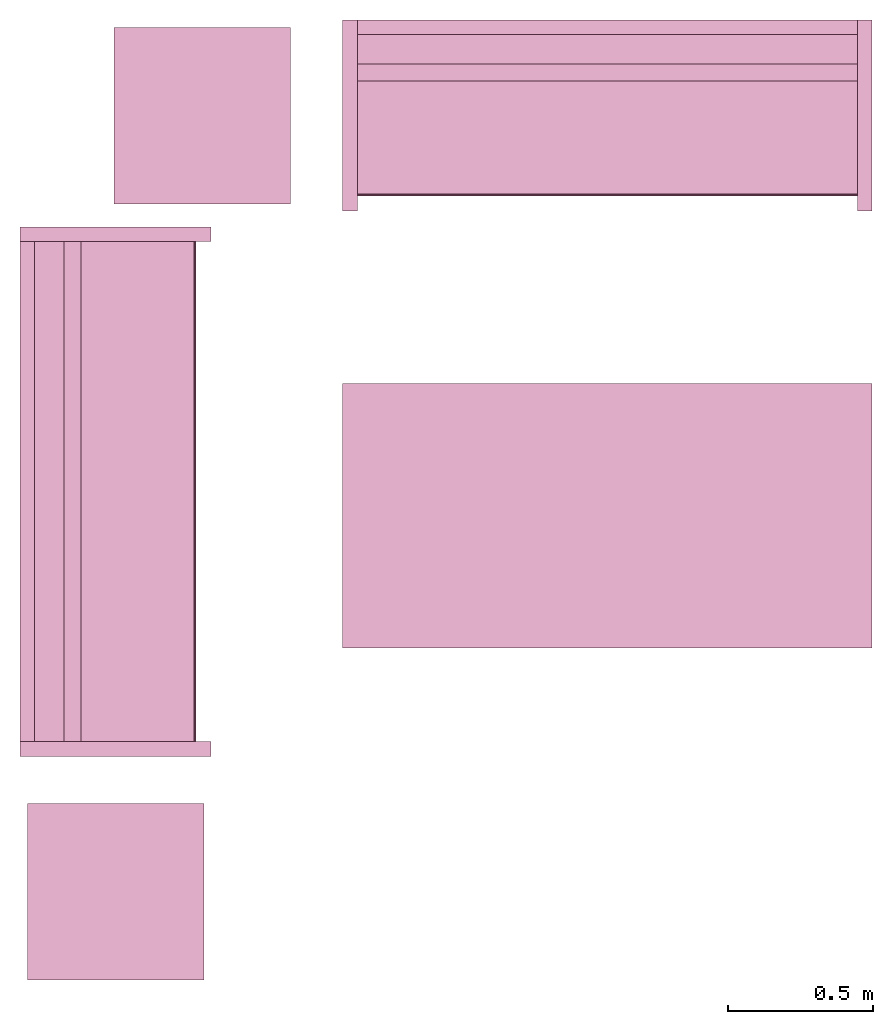
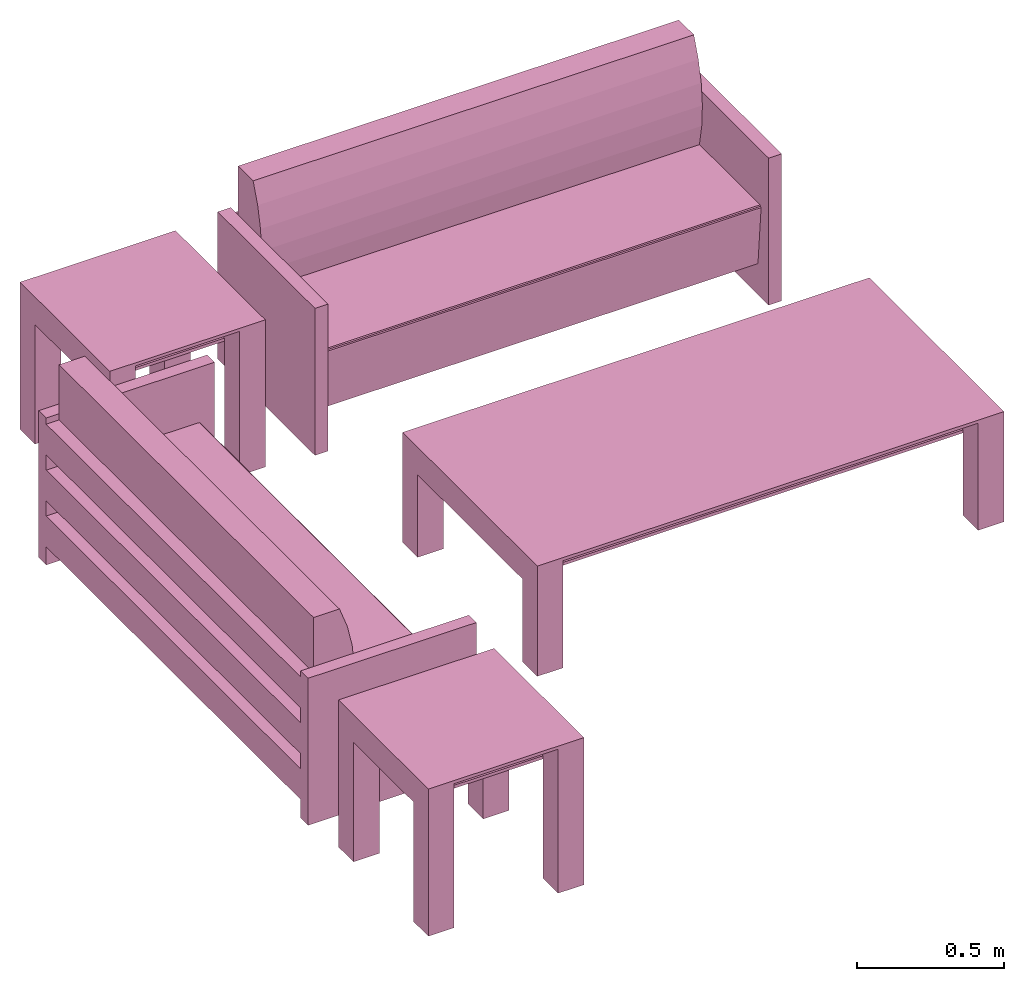
# One storey: 5 furnishings.
"""IFC2X3 building model written with IfcOpenShell, lengths in metres."""

from ifc_helpers import new_model, entity, si_unit, converted_unit, frame, origin, origin_with_axes, origin_2d_with_axis, place, context, project, spatial, polyline, rectangle, outline, extrude, face_set, surface_model, source, transform, mapped, type_object, type_shapes, element, save


model = new_model("IFC2X3")

# Units and contexts
model_context = context("Model", 3, precision=1e-09, world=origin())
plan_context = context("Plan", 3, precision=1e-09, world=origin())
ifc_project = project(units=[si_unit("LENGTHUNIT", "METRE"), si_unit("AREAUNIT", "SQUARE_METRE"), si_unit("VOLUMEUNIT", "CUBIC_METRE"), converted_unit("PLANEANGLEUNIT", "DEGREE", entity("IfcRatioMeasure", 0.0174532925199433), si_unit("PLANEANGLEUNIT", "RADIAN"), dimensions=[0, 0, 0, 0, 0, 0, 0]), si_unit("TIMEUNIT", "SECOND")], contexts=[model_context, plan_context])

# Site, building, storey, space
site_placement = place(None, origin_with_axes())
site = spatial("IfcSite", under=ifc_project, at=site_placement, CompositionType="ELEMENT")
building_placement = place(None, origin_with_axes())
building = spatial("IfcBuilding", under=site, at=building_placement, CompositionType="ELEMENT")
storey_placement = place(None, origin_with_axes())
storey = spatial("IfcBuildingStorey", under=building, at=storey_placement, Name="Level 1", CompositionType="ELEMENT", Elevation=0.0)
space_placement = place(None, origin_with_axes())
space = spatial("IfcSpace", under=storey, at=space_placement, CompositionType="ELEMENT", InteriorOrExteriorSpace="INTERNAL")

# Furnishings
furniture_type_1 = type_object("IfcFurnitureType", Name="1830mm", AssemblyPlace="NOTDEFINED")
shared_shape_1 = source(origin(), model_context, "Body", "SurfaceModel", [
    surface_model("IfcFaceBasedSurfaceModel", [(0.0507999999999982, 0.609599999999997, 0.5842), (0.0507999999999983, 0.660399999999998, 0.5842), (0.0507999999999983, 0.660399999999998, 0.4572), (0.0507999999999982, 0.609599999999997, 0.4572), (0.0507999999999982, 0.609599999999998, 0.3937), (0.0507999999999983, 0.660399999999998, 0.3937), (0.0507999999999983, 0.660399999999998, 0.2667), (0.0507999999999982, 0.609599999999998, 0.2667), (0.0507999999999982, 0.609600000000004, 0.2032), (0.0507999999999983, 0.660399999999998, 0.2032), (0.0507999999999983, 0.660399999999998, 0.0762), (0.0507999999999982, 0.609600000000004, 0.0762), (1.77919999999999, 0.609599999999994, 0.5842), (1.77919999999999, 0.609599999999994, 0.4572), (1.77919999999999, 0.660399999999995, 0.4572), (1.77919999999999, 0.660399999999995, 0.5842), (1.77919999999999, 0.609599999999995, 0.3937), (1.77919999999999, 0.609599999999995, 0.2667), (1.77919999999999, 0.660399999999995, 0.2667), (1.77919999999999, 0.660399999999995, 0.3937), (1.77919999999999, 0.609600000000001, 0.2032), (1.77919999999999, 0.609600000000001, 0.0762), (1.77919999999999, 0.660399999999995, 0.0762), (1.77919999999999, 0.660399999999995, 0.2032), (0.0507999999999978, 0.470222395089521, 0.380999999999998), (0.0507999999999978, 0.454401348887885, 0.467831162756508), (0.0507999999999978, 0.450300415835913, 0.555996567971167), (0.0507999999999978, 0.457992845249543, 0.643921438504357), (0.0507999999999978, 0.477341237862486, 0.730035293556011), (0.0507999999999979, 0.507999999999975, 0.812799999999995), (0.0507999999999981, 0.609599999999998, 0.812799999999998), (0.0507999999999981, 0.609599999999998, 0.127966546684697), (0.0507999999999971, 0.0729375586579064, 0.127966546684697), (0.0507999999999971, 0.0520079452978146, 0.367193122067106), (0.0507999999999971, 0.0526336053189921, 0.372382281209352), (0.0507999999999971, 0.0552961957860913, 0.37687999563672), (0.0507999999999971, 0.0595447350023739, 0.379924455784818), (0.0507999999999971, 0.0646596179635799, 0.381000000000001), (1.77919999999998, 0.470222395089517, 0.381000000000001), (1.77919999999998, 0.0646596179635769, 0.381000000000001), (1.77919999999998, 0.059544735002371, 0.379924455784818), (1.77919999999998, 0.0552961957860883, 0.37687999563672), (1.77919999999998, 0.0526336053189891, 0.372382281209352), (1.77919999999998, 0.0520079452978117, 0.367193122067106), (1.77919999999998, 0.0729375586579034, 0.127966546684697), (1.77919999999998, 0.609599999999995, 0.127966546684697), (1.77919999999998, 0.609599999999995, 0.812799999999998), (1.77919999999998, 0.507999999999972, 0.812799999999995), (1.77919999999998, 0.477341237862483, 0.730035293556011), (1.77919999999998, 0.45799284524954, 0.643921438504357), (1.77919999999998, 0.45030041583591, 0.555996567971167), (1.77919999999998, 0.454401348887882, 0.467831162756508), (0.050799984484911, 0.0539648979902268, 0.374631136655807), (1.77919995784759, 0.0539648979902268, 0.374631136655807), (0.050799984484911, 0.0523207746446133, 0.369787722826004), (1.77919995784759, 0.0523207746446133, 0.369787722826004), (1.77919995784759, 0.0621021725237369, 0.380462229251862), (0.050799984484911, 0.0621788389980793, 0.380478352308273), (1.77919995784759, 0.0574204623699188, 0.378402233123779), (0.050799984484911, 0.0574204623699188, 0.378402233123779), (0.0507999999999971, 0.660399999999997, 0.6096), (0.0507999999999971, 0.0, 0.6096), (0.0, 0.0, 0.6096), (0.0, 0.660399999999997, 0.6096), (1.83, 0.660400000000039, 0.6096), (1.83, 0.0, 0.6096), (1.77919999999997, 0.0, 0.6096), (1.77919999999997, 0.660400000000039, 0.6096), (0.0507999999999971, 0.660399999999997, 0.0), (0.0507999999999971, 0.0, 0.0), (0.0, 0.0, 0.0), (0.0, 0.660399999999997, 0.0), (1.83, 0.660400000000039, 0.0), (1.83, 0.0, 0.0), (1.77919999999997, 0.0, 0.0), (1.77919999999997, 0.660400000000039, 0.0)], [face_set([[[0, 1, 2, 3]], [[4, 5, 6, 7]], [[8, 9, 10, 11]], [[12, 13, 14, 15]], [[16, 17, 18, 19]], [[20, 21, 22, 23]], [[1, 15, 12, 0]], [[2, 14, 15, 1]], [[3, 2, 14, 13]], [[0, 3, 13, 12]], [[5, 19, 16, 4]], [[6, 18, 19, 5]], [[7, 6, 18, 17]], [[4, 7, 17, 16]], [[9, 23, 20, 8]], [[10, 22, 23, 9]], [[11, 10, 22, 21]], [[8, 11, 21, 20]]]), face_set([[[24, 25, 26, 27, 28, 29, 30, 31, 32, 33, 34, 35, 36, 37]], [[38, 39, 40, 41, 42, 43, 44, 45, 46, 47, 48, 49, 50, 51]], [[24, 25, 51, 38]], [[25, 26, 50, 51]], [[49, 50, 26, 27]], [[27, 28, 48, 49]], [[28, 29, 47, 48]], [[30, 46, 47, 29]], [[31, 30, 46, 45]], [[32, 31, 45, 44]], [[33, 32, 44, 43]], [[41, 35, 52, 53]], [[54, 55, 42, 34]], [[33, 43, 55, 54]], [[34, 42, 53, 52]], [[39, 56, 57]], [[35, 41, 58, 59]], [[56, 40, 36]], [[57, 37, 39]], [[57, 56, 36]], [[40, 36, 59, 58]], [[24, 38, 39, 37]]]), face_set([[[60, 61, 62, 63]], [[64, 65, 66, 67]], [[68, 69, 70, 71]], [[72, 73, 74, 75]], [[63, 60, 68, 71]], [[62, 63, 71, 70]], [[61, 62, 70, 69]], [[60, 68, 69, 61]], [[67, 64, 72, 75]], [[66, 74, 75, 67]], [[65, 66, 74, 73]], [[64, 65, 73, 72]]])]),
])
type_shapes(furniture_type_1, [shared_shape_1])
for number, where, z_axis, x_axis, name in (
    (1, (1.68589931406676, -14.3855826647373, 0.0), (0.0, 0.0, 1.0), (1.0, 0.0, 0.0), "M_Sofa:1830mm:1830mm"),
    (2, (1.23109931406676, -16.2703826647373, 0.0), (0.0, 0.0, 1.0), (0.0, 1.0, 0.0), "M_Sofa:1830mm:1830mm"),
):
    element("IfcFurnishingElement", number, at=place(None, frame(where, z_axis=z_axis, x_axis=x_axis)), inside=space, type_object=furniture_type_1, Name=name, context=model_context, shape_type="MappedRepresentation", body=[
        mapped(shared_shape_1, transform((0.0, 0.0, 0.0), scale=1.0)),
    ])
furniture_type_2 = type_object("IfcFurnitureType", Name="0610 x 0610 x 0610mm", AssemblyPlace="NOTDEFINED")
shared_shape_2 = source(origin(), model_context, "Body", "SweptSolid", [
    extrude(rectangle(XDim=0.406799999999999, YDim=0.406799999999999, at=origin_2d_with_axis()), frame((0.0182657666726316, 0.0952110778022263, 0.4957), z_axis=(0.0, 0.0, 1.0), x_axis=(-1.0, 0.0, 0.0)), (0.0, 0.0, 1.0), 0.0127),
    extrude(outline(polyline([(-0.273249999999994, -0.305), (0.324049999999978, -0.305), (0.324049999999978, 0.304999999999998), (-0.273249999999993, 0.304999999999999), (-0.273249999999993, 0.203400000000001), (0.222450000000009, 0.203400000000001), (0.222450000000009, -0.2034), (-0.273249999999994, -0.2034), (-0.273249999999994, -0.305)])), frame((0.221665766672633, 0.0952110778022354, 0.273249999999992), z_axis=(1.0, 0.0, 0.0), x_axis=(0.0, 0.0, 1.0)), (0.0, 0.0, 1.0), 0.1016),
    extrude(outline(polyline([(-0.305000000000004, -0.324050000000025), (0.304999999999994, -0.324050000000025), (0.304999999999994, 0.273250000000011), (0.203400000000004, 0.273250000000011), (0.203400000000004, -0.222449999999996), (-0.203399999999995, -0.222449999999996), (-0.203399999999995, 0.273250000000011), (-0.305000000000004, 0.273250000000011), (-0.305000000000004, -0.324050000000025)])), frame((-0.286734233327367, 0.0952110778022256, 0.273250000000008), z_axis=(1.0, 0.0, 0.0), x_axis=(0.0, -1.0, 0.0)), (0.0, 0.0, 1.0), 0.1016),
    extrude(rectangle(XDim=0.406799999999999, YDim=0.406799999999999, at=origin_2d_with_axis()), frame((0.0182657666726316, 0.0952110778022259, 0.5973), z_axis=(0.0, 0.0, 1.0), x_axis=(-1.0, 0.0, 0.0)), (0.0, 0.0, 1.0), 0.0127),
    extrude(outline(polyline([(-0.305, -0.305000000000023), (0.305, -0.305000000000023), (0.305, 0.305000000000023), (-0.305, 0.305000000000023), (-0.305, -0.305000000000023)]), holes=[polyline([(-0.203399999999998, -0.203399999999975), (-0.203399999999998, 0.203400000000025), (0.203400000000001, 0.203400000000025), (0.203400000000001, -0.203399999999975), (-0.203399999999998, -0.203399999999975)])]), frame((0.0182657666726332, 0.0952110778022508, 0.5973), z_axis=(0.0, 0.0, 1.0), x_axis=(-1.0, 0.0, 0.0)), (0.0, 0.0, 1.0), 0.0127),
])
type_shapes(furniture_type_2, [shared_shape_2])
for number, where, z_axis, x_axis, name in (
    (3, (1.21916508073938, -13.9601715869351, 0.0), (0.0, 0.0, 1.0), (-1.0, 0.0, 0.0), "M_Table-Coffee:0610 x 0610 x 0610mm:0610 x 0610 x 0610mm"),
    (4, (0.919165080739398, -16.6431715869351, 0.0), (0.0, 0.0, 1.0), (-1.0, 0.0, 0.0), "M_Table-Coffee:0610 x 0610 x 0610mm:0610 x 0610 x 0610mm"),
):
    element("IfcFurnishingElement", number, at=place(None, frame(where, z_axis=z_axis, x_axis=x_axis)), inside=space, type_object=furniture_type_2, Name=name, context=model_context, shape_type="MappedRepresentation", body=[
        mapped(shared_shape_2, transform((0.0, 0.0, 0.0), scale=1.0)),
    ])
furniture_type_3 = type_object("IfcFurnitureType", Name="0915 x 1830 x 0457mm", AssemblyPlace="NOTDEFINED")
shared_shape_3 = source(origin(), model_context, "Body", "SweptSolid", [
    extrude(rectangle(XDim=1.6268, YDim=0.711799999999999, at=origin_2d_with_axis()), frame((0.0182657666726317, 0.0952110778022268, 0.3427), z_axis=(0.0, 0.0, 1.0), x_axis=(-1.0, 0.0, 0.0)), (0.0, 0.0, 1.0), 0.0127),
    extrude(outline(polyline([(-0.196749999999994, -0.4575), (0.247549999999978, -0.4575), (0.247549999999978, 0.457499999999999), (-0.196749999999993, 0.457499999999999), (-0.196749999999993, 0.355900000000002), (0.145950000000009, 0.355900000000001), (0.145950000000009, -0.3559), (-0.196749999999994, -0.3559), (-0.196749999999994, -0.4575)])), frame((0.831665766672632, 0.0952110778022354, 0.196749999999991), z_axis=(1.0, 0.0, 0.0), x_axis=(0.0, 0.0, 1.0)), (0.0, 0.0, 1.0), 0.1016),
    extrude(outline(polyline([(-0.457500000000004, -0.247550000000026), (0.457499999999994, -0.247550000000026), (0.457499999999994, 0.196750000000011), (0.355900000000004, 0.196750000000011), (0.355900000000004, -0.145949999999996), (-0.355899999999994, -0.145949999999996), (-0.355899999999994, 0.196750000000011), (-0.457500000000004, 0.196750000000011), (-0.457500000000004, -0.247550000000026)])), frame((-0.896734233327367, 0.0952110778022256, 0.196750000000009), z_axis=(1.0, 0.0, 0.0), x_axis=(0.0, -1.0, 0.0)), (0.0, 0.0, 1.0), 0.1016),
    extrude(rectangle(XDim=1.6268, YDim=0.711799999999999, at=origin_2d_with_axis()), frame((0.0182657666726317, 0.0952110778022265, 0.4443), z_axis=(0.0, 0.0, 1.0), x_axis=(-1.0, 0.0, 0.0)), (0.0, 0.0, 1.0), 0.0127),
    extrude(outline(polyline([(-0.915, -0.457500000000023), (0.915, -0.457500000000023), (0.915, 0.457500000000023), (-0.915, 0.457500000000023), (-0.915, -0.457500000000023)]), holes=[polyline([(-0.813399999999998, -0.355899999999975), (-0.813399999999998, 0.355900000000025), (0.813400000000001, 0.355900000000024), (0.813400000000001, -0.355899999999975), (-0.813399999999998, -0.355899999999975)])]), frame((0.0182657666726332, 0.0952110778022514, 0.4443), z_axis=(0.0, 0.0, 1.0), x_axis=(-1.0, 0.0, 0.0)), (0.0, 0.0, 1.0), 0.0127),
])
type_shapes(furniture_type_3, [shared_shape_3])
furnishing_placement = place(None, frame((2.61916508073939, -15.3431715869351, 0.0), z_axis=(0.0, 0.0, 1.0), x_axis=(-1.0, 0.0, 0.0)))
element("IfcFurnishingElement", 5, at=furnishing_placement, inside=space, type_object=furniture_type_3, Name="M_Table-Coffee:0915 x 1830 x 0457mm:0915 x 1830 x 0457mm", context=model_context, shape_type="MappedRepresentation", body=[
    mapped(shared_shape_3, transform((0.0, 0.0, 0.0), scale=1.0)),
])

save(model, "model.ifc")
